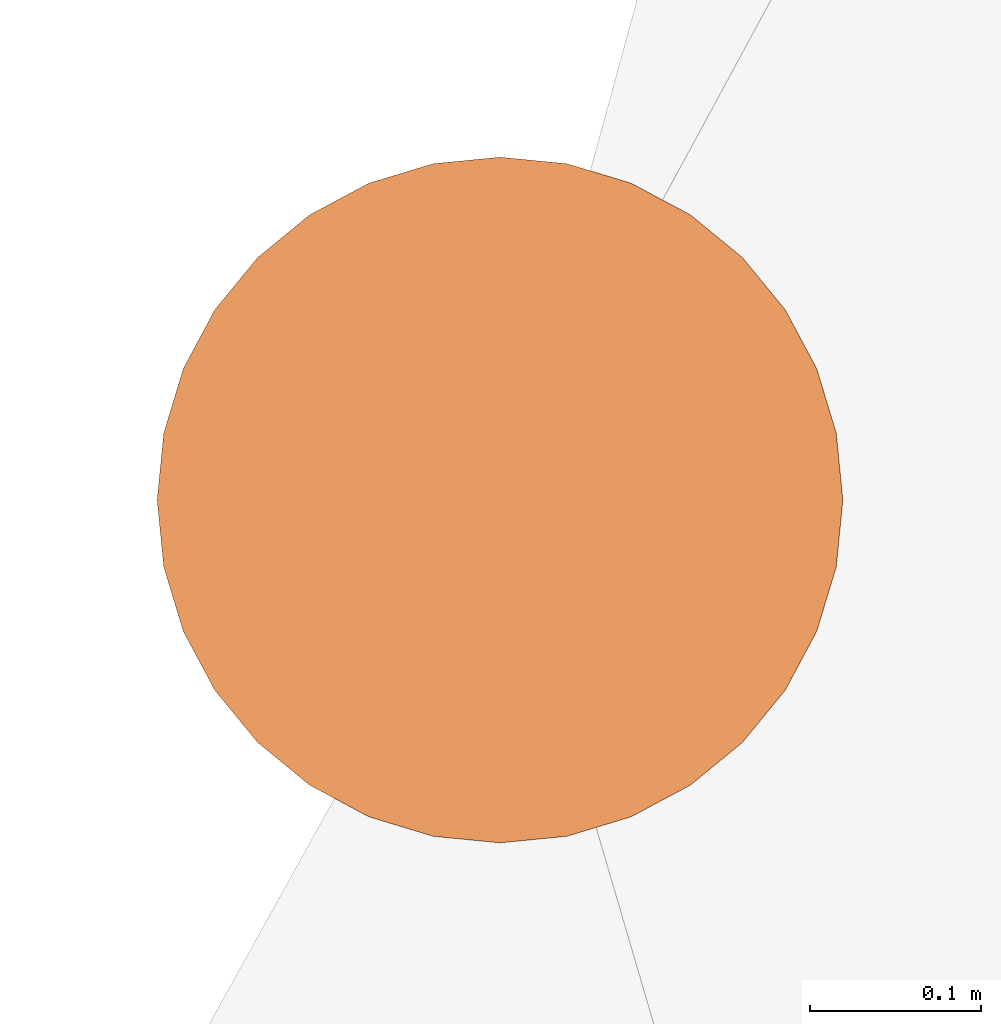
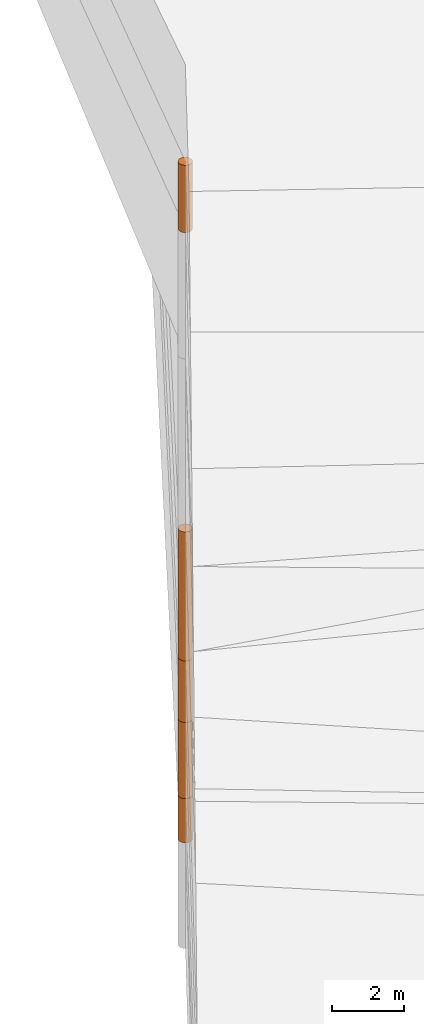
# One storey, part 10 of 24: 5 geographic elements.
"""IFC4 building model written with IfcOpenShell, lengths in metres."""

from ifc_helpers import new_model, entity, si_unit, converted_unit, frame, origin_with_axes, origin_2d_with_axis, place, context, subcontext, project, spatial, polygons, element, save


model = new_model("IFC4")

# Units and contexts
model_context = context("Model", 3, precision=1e-05, world=origin_with_axes())
plan_context = context("Plan", 2, precision=1e-05, world=origin_2d_with_axis())
body_context = subcontext(model_context, "Body", "Model", "MODEL_VIEW")
ifc_project = project(units=[converted_unit("PLANEANGLEUNIT", "degree", entity("IfcReal", 0.0174532925199433), si_unit("PLANEANGLEUNIT", "RADIAN"), dimensions=[0, 0, 0, 0, 0, 0, 0]), si_unit("AREAUNIT", "SQUARE_METRE"), si_unit("VOLUMEUNIT", "CUBIC_METRE"), si_unit("LENGTHUNIT", "METRE")], contexts=[model_context, plan_context])

# Site, building, storey
site_placement = place(None, origin_with_axes())
site = spatial("IfcSite", under=ifc_project, at=site_placement)
building_placement = place(site_placement, origin_with_axes())
building = spatial("IfcBuilding", under=site, at=building_placement, Name="Building")
storey_placement = place(building_placement, origin_with_axes())
storey = spatial("IfcBuildingStorey", under=building, at=storey_placement, Name="Storey")

# Geographic elements
geographic_element_1_placement = place(storey_placement, frame((0.699999988079071, 56.4000015258789, 14.952000617981), z_axis=(0.0, 0.0, 1.0), x_axis=(1.0, 0.0, 0.0)))
element("IfcGeographicElement", 1, at=geographic_element_1_placement, inside=storey, PredefinedType="NOTDEFINED", context=body_context, shape_type="Tessellation", body=[
    polygons([(0.0, 0.0, -1.14900004863739), (0.0390180610120296, 0.196157038211823, -1.14900004863739), (0.0, 0.199999988079071, -1.14900004863739), (0.0, 0.0, 1.14900004863739), (0.0, 0.199999988079071, 1.14900004863739), (0.0390180610120296, 0.196157038211823, 1.14900004863739), (0.0765366926789284, 0.18477588891983, -1.14900004863739), (0.0765366926789284, 0.18477588891983, 1.14900004863739), (0.111114047467709, 0.166293919086456, -1.14900004863739), (0.111114047467709, 0.166293919086456, 1.14900004863739), (0.141421362757683, 0.141421362757683, -1.14900004863739), (0.141421362757683, 0.141421362757683, 1.14900004863739), (0.166293919086456, 0.111114047467709, -1.14900004863739), (0.166293919086456, 0.111114047467709, 1.14900004863739), (0.18477588891983, 0.0765366926789284, -1.14900004863739), (0.18477588891983, 0.0765366926789284, 1.14900004863739), (0.196157038211823, 0.0390180610120296, -1.14900004863739), (0.196157038211823, 0.0390180610120296, 1.14900004863739), (0.199999988079071, 0.0, -1.14900004863739), (0.199999988079071, 0.0, 1.14900004863739), (0.196157038211823, -0.0390180610120296, -1.14900004863739), (0.196157038211823, -0.0390180610120296, 1.14900004863739), (0.18477588891983, -0.0765366926789284, -1.14900004863739), (0.18477588891983, -0.0765366926789284, 1.14900004863739), (0.166293919086456, -0.111114047467709, -1.14900004863739), (0.166293919086456, -0.111114047467709, 1.14900004863739), (0.141421362757683, -0.141421362757683, -1.14900004863739), (0.141421362757683, -0.141421362757683, 1.14900004863739), (0.111114047467709, -0.166293919086456, -1.14900004863739), (0.111114047467709, -0.166293919086456, 1.14900004863739), (0.0765366926789284, -0.18477588891983, -1.14900004863739), (0.0765366926789284, -0.18477588891983, 1.14900004863739), (0.0390180610120296, -0.196157038211823, -1.14900004863739), (0.0390180610120296, -0.196157038211823, 1.14900004863739), (0.0, -0.199999988079071, -1.14900004863739), (0.0, -0.199999988079071, 1.14900004863739), (-0.0390180610120296, -0.196157038211823, -1.14900004863739), (-0.0390180610120296, -0.196157038211823, 1.14900004863739), (-0.0765366926789284, -0.18477588891983, -1.14900004863739), (-0.0765366926789284, -0.18477588891983, 1.14900004863739), (-0.111114047467709, -0.166293919086456, -1.14900004863739), (-0.111114047467709, -0.166293919086456, 1.14900004863739), (-0.141421362757683, -0.141421362757683, -1.14900004863739), (-0.141421362757683, -0.141421362757683, 1.14900004863739), (-0.166293919086456, -0.111114047467709, -1.14900004863739), (-0.166293919086456, -0.111114047467709, 1.14900004863739), (-0.18477588891983, -0.0765366926789284, -1.14900004863739), (-0.18477588891983, -0.0765366926789284, 1.14900004863739), (-0.196157038211823, -0.0390180610120296, -1.14900004863739), (-0.196157038211823, -0.0390180610120296, 1.14900004863739), (-0.199999988079071, 0.0, -1.14900004863739), (-0.199999988079071, 0.0, 1.14900004863739), (-0.196157038211823, 0.0390180610120296, -1.14900004863739), (-0.196157038211823, 0.0390180610120296, 1.14900004863739), (-0.18477588891983, 0.0765366926789284, -1.14900004863739), (-0.18477588891983, 0.0765366926789284, 1.14900004863739), (-0.166293919086456, 0.111114047467709, -1.14900004863739), (-0.166293919086456, 0.111114047467709, 1.14900004863739), (-0.141421362757683, 0.141421362757683, -1.14900004863739), (-0.141421362757683, 0.141421362757683, 1.14900004863739), (-0.111114047467709, 0.166293919086456, -1.14900004863739), (-0.111114047467709, 0.166293919086456, 1.14900004863739), (-0.0765366926789284, 0.18477588891983, -1.14900004863739), (-0.0765366926789284, 0.18477588891983, 1.14900004863739), (-0.0390180610120296, 0.196157038211823, -1.14900004863739), (-0.0390180610120296, 0.196157038211823, 1.14900004863739)], [[[3, 2, 1]], [[6, 5, 4]], [[28, 30, 29, 27]], [[2, 7, 1]], [[8, 6, 4]], [[64, 66, 65, 63]], [[7, 9, 1]], [[10, 8, 4]], [[9, 11, 1]], [[12, 10, 4]], [[6, 8, 7, 2]], [[1, 11, 13]], [[12, 4, 14]], [[66, 5, 3, 65]], [[1, 13, 15]], [[4, 16, 14]], [[12, 14, 13, 11]], [[1, 15, 17]], [[4, 18, 16]], [[14, 16, 15, 13]], [[1, 17, 19]], [[4, 20, 18]], [[16, 18, 17, 15]], [[1, 19, 21]], [[4, 22, 20]], [[18, 20, 19, 17]], [[1, 21, 23]], [[4, 24, 22]], [[20, 22, 21, 19]], [[1, 23, 25]], [[4, 26, 24]], [[22, 24, 23, 21]], [[1, 25, 27]], [[4, 28, 26]], [[24, 26, 25, 23]], [[1, 27, 29]], [[28, 4, 30]], [[26, 28, 27, 25]], [[1, 29, 31]], [[4, 32, 30]], [[5, 6, 2, 3]], [[1, 31, 33]], [[4, 34, 32]], [[30, 32, 31, 29]], [[1, 33, 35]], [[4, 36, 34]], [[8, 10, 9, 7]], [[1, 35, 37]], [[4, 38, 36]], [[32, 34, 33, 31]], [[1, 37, 39]], [[4, 40, 38]], [[36, 38, 37, 35]], [[1, 39, 41]], [[4, 42, 40]], [[38, 40, 39, 37]], [[43, 1, 41]], [[4, 44, 42]], [[40, 42, 41, 39]], [[43, 45, 1]], [[4, 46, 44]], [[42, 44, 43, 41]], [[45, 47, 1]], [[48, 46, 4]], [[44, 46, 45, 43]], [[47, 49, 1]], [[50, 48, 4]], [[46, 48, 47, 45]], [[49, 51, 1]], [[52, 50, 4]], [[48, 50, 49, 47]], [[51, 53, 1]], [[54, 52, 4]], [[50, 52, 51, 49]], [[53, 55, 1]], [[56, 54, 4]], [[52, 54, 53, 51]], [[55, 57, 1]], [[58, 56, 4]], [[54, 56, 55, 53]], [[59, 1, 57]], [[60, 58, 4]], [[56, 58, 57, 55]], [[59, 61, 1]], [[62, 60, 4]], [[58, 60, 59, 57]], [[61, 63, 1]], [[64, 62, 4]], [[60, 62, 61, 59]], [[63, 65, 1]], [[66, 64, 4]], [[62, 64, 63, 61]], [[65, 3, 1]], [[5, 66, 4]], [[34, 36, 35, 33]], [[10, 12, 11, 9]]]),
])
geographic_element_2_placement = place(storey_placement, frame((0.700000047683716, 56.4000015258789, -6.23850202560425), z_axis=(0.0, 0.0, 1.0), x_axis=(1.0, 0.0, 0.0)))
element("IfcGeographicElement", 2, at=geographic_element_2_placement, inside=storey, PredefinedType="NOTDEFINED", context=body_context, shape_type="Tessellation", body=[
    polygons([(0.0, 0.0, -0.751500070095062), (0.0390180610120296, 0.196157038211823, -0.751500070095062), (0.0, 0.199999988079071, -0.751500070095062), (0.0, 0.0, 0.751500070095062), (0.0, 0.199999988079071, 0.751500070095062), (0.0390180610120296, 0.196157038211823, 0.751500070095062), (0.0765366926789284, 0.18477588891983, -0.751500070095062), (0.0765366926789284, 0.18477588891983, 0.751500070095062), (0.111114047467709, 0.166293919086456, -0.751500070095062), (0.111114047467709, 0.166293919086456, 0.751500070095062), (0.141421362757683, 0.141421362757683, -0.751500070095062), (0.141421362757683, 0.141421362757683, 0.751500070095062), (0.166293919086456, 0.111114047467709, -0.751500070095062), (0.166293919086456, 0.111114047467709, 0.751500070095062), (0.18477588891983, 0.0765366926789284, -0.751500070095062), (0.18477588891983, 0.0765366926789284, 0.751500070095062), (0.196157038211823, 0.0390180610120296, -0.751500070095062), (0.196157038211823, 0.0390180610120296, 0.751500070095062), (0.199999988079071, 0.0, -0.751500070095062), (0.199999988079071, 0.0, 0.751500070095062), (0.196157038211823, -0.0390180610120296, -0.751500070095062), (0.196157038211823, -0.0390180610120296, 0.751500070095062), (0.18477588891983, -0.0765366926789284, -0.751500070095062), (0.18477588891983, -0.0765366926789284, 0.751500070095062), (0.166293919086456, -0.111114047467709, -0.751500070095062), (0.166293919086456, -0.111114047467709, 0.751500070095062), (0.141421362757683, -0.141421362757683, -0.751500070095062), (0.141421362757683, -0.141421362757683, 0.751500070095062), (0.111114047467709, -0.166293919086456, -0.751500070095062), (0.111114047467709, -0.166293919086456, 0.751500070095062), (0.0765366926789284, -0.18477588891983, -0.751500070095062), (0.0765366926789284, -0.18477588891983, 0.751500070095062), (0.0390180610120296, -0.196157038211823, -0.751500070095062), (0.0390180610120296, -0.196157038211823, 0.751500070095062), (0.0, -0.199999988079071, -0.751500070095062), (0.0, -0.199999988079071, 0.751500070095062), (-0.0390180610120296, -0.196157038211823, -0.751500070095062), (-0.0390180610120296, -0.196157038211823, 0.751500070095062), (-0.0765366926789284, -0.18477588891983, -0.751500070095062), (-0.0765366926789284, -0.18477588891983, 0.751500070095062), (-0.111114047467709, -0.166293919086456, -0.751500070095062), (-0.111114047467709, -0.166293919086456, 0.751500070095062), (-0.141421362757683, -0.141421362757683, -0.751500070095062), (-0.141421362757683, -0.141421362757683, 0.751500070095062), (-0.166293919086456, -0.111114047467709, -0.751500070095062), (-0.166293919086456, -0.111114047467709, 0.751500070095062), (-0.18477588891983, -0.0765366926789284, -0.751500070095062), (-0.18477588891983, -0.0765366926789284, 0.751500070095062), (-0.196157038211823, -0.0390180610120296, -0.751500070095062), (-0.196157038211823, -0.0390180610120296, 0.751500070095062), (-0.199999988079071, 0.0, -0.751500070095062), (-0.199999988079071, 0.0, 0.751500070095062), (-0.196157038211823, 0.0390180610120296, -0.751500070095062), (-0.196157038211823, 0.0390180610120296, 0.751500070095062), (-0.18477588891983, 0.0765366926789284, -0.751500070095062), (-0.18477588891983, 0.0765366926789284, 0.751500070095062), (-0.166293919086456, 0.111114047467709, -0.751500070095062), (-0.166293919086456, 0.111114047467709, 0.751500070095062), (-0.141421362757683, 0.141421362757683, -0.751500070095062), (-0.141421362757683, 0.141421362757683, 0.751500070095062), (-0.111114047467709, 0.166293919086456, -0.751500070095062), (-0.111114047467709, 0.166293919086456, 0.751500070095062), (-0.0765366926789284, 0.18477588891983, -0.751500070095062), (-0.0765366926789284, 0.18477588891983, 0.751500070095062), (-0.0390180610120296, 0.196157038211823, -0.751500070095062), (-0.0390180610120296, 0.196157038211823, 0.751500070095062)], [[[3, 2, 1]], [[6, 5, 4]], [[28, 30, 29, 27]], [[2, 7, 1]], [[8, 6, 4]], [[64, 66, 65, 63]], [[7, 9, 1]], [[10, 8, 4]], [[9, 11, 1]], [[12, 10, 4]], [[6, 8, 7, 2]], [[1, 11, 13]], [[12, 4, 14]], [[66, 5, 3, 65]], [[1, 13, 15]], [[14, 4, 16]], [[12, 14, 13, 11]], [[1, 15, 17]], [[16, 4, 18]], [[14, 16, 15, 13]], [[1, 17, 19]], [[4, 20, 18]], [[16, 18, 17, 15]], [[1, 19, 21]], [[4, 22, 20]], [[18, 20, 19, 17]], [[1, 21, 23]], [[22, 4, 24]], [[20, 22, 21, 19]], [[1, 23, 25]], [[24, 4, 26]], [[22, 24, 23, 21]], [[27, 1, 25]], [[4, 28, 26]], [[24, 26, 25, 23]], [[1, 27, 29]], [[28, 4, 30]], [[26, 28, 27, 25]], [[1, 29, 31]], [[4, 32, 30]], [[5, 6, 2, 3]], [[1, 31, 33]], [[4, 34, 32]], [[30, 32, 31, 29]], [[1, 33, 35]], [[4, 36, 34]], [[8, 10, 9, 7]], [[1, 35, 37]], [[4, 38, 36]], [[32, 34, 33, 31]], [[1, 37, 39]], [[4, 40, 38]], [[36, 38, 37, 35]], [[1, 39, 41]], [[4, 42, 40]], [[38, 40, 39, 37]], [[43, 1, 41]], [[4, 44, 42]], [[40, 42, 41, 39]], [[43, 45, 1]], [[46, 44, 4]], [[42, 44, 43, 41]], [[47, 1, 45]], [[4, 48, 46]], [[44, 46, 45, 43]], [[49, 1, 47]], [[4, 50, 48]], [[46, 48, 47, 45]], [[49, 51, 1]], [[52, 50, 4]], [[48, 50, 49, 47]], [[51, 53, 1]], [[54, 52, 4]], [[50, 52, 51, 49]], [[55, 1, 53]], [[4, 56, 54]], [[52, 54, 53, 51]], [[57, 1, 55]], [[4, 58, 56]], [[54, 56, 55, 53]], [[57, 59, 1]], [[60, 58, 4]], [[56, 58, 57, 55]], [[59, 61, 1]], [[62, 60, 4]], [[58, 60, 59, 57]], [[61, 63, 1]], [[64, 62, 4]], [[60, 62, 61, 59]], [[63, 65, 1]], [[66, 64, 4]], [[62, 64, 63, 61]], [[65, 3, 1]], [[5, 66, 4]], [[34, 36, 35, 33]], [[10, 12, 11, 9]]]),
])
geographic_element_3_placement = place(storey_placement, frame((0.700000047683716, 56.4000015258789, -4.18800163269043), z_axis=(0.0, 0.0, 1.0), x_axis=(1.0, 0.0, 0.0)))
element("IfcGeographicElement", 3, at=geographic_element_3_placement, inside=storey, PredefinedType="NOTDEFINED", context=body_context, shape_type="Tessellation", body=[
    polygons([(0.0, 0.0, -1.29900014400482), (0.0390180610120296, 0.196157038211823, -1.29900014400482), (0.0, 0.199999988079071, -1.29900014400482), (0.0, 0.0, 1.29900014400482), (0.0, 0.199999988079071, 1.29900014400482), (0.0390180610120296, 0.196157038211823, 1.29900014400482), (0.0765366926789284, 0.18477588891983, -1.29900014400482), (0.0765366926789284, 0.18477588891983, 1.29900014400482), (0.111114047467709, 0.166293919086456, -1.29900014400482), (0.111114047467709, 0.166293919086456, 1.29900014400482), (0.141421362757683, 0.141421362757683, -1.29900014400482), (0.141421362757683, 0.141421362757683, 1.29900014400482), (0.166293919086456, 0.111114047467709, -1.29900014400482), (0.166293919086456, 0.111114047467709, 1.29900014400482), (0.18477588891983, 0.0765366926789284, -1.29900014400482), (0.18477588891983, 0.0765366926789284, 1.29900014400482), (0.196157038211823, 0.0390180610120296, -1.29900014400482), (0.196157038211823, 0.0390180610120296, 1.29900014400482), (0.199999988079071, 0.0, -1.29900014400482), (0.199999988079071, 0.0, 1.29900014400482), (0.196157038211823, -0.0390180610120296, -1.29900014400482), (0.196157038211823, -0.0390180610120296, 1.29900014400482), (0.18477588891983, -0.0765366926789284, -1.29900014400482), (0.18477588891983, -0.0765366926789284, 1.29900014400482), (0.166293919086456, -0.111114047467709, -1.29900014400482), (0.166293919086456, -0.111114047467709, 1.29900014400482), (0.141421362757683, -0.141421362757683, -1.29900014400482), (0.141421362757683, -0.141421362757683, 1.29900014400482), (0.111114047467709, -0.166293919086456, -1.29900014400482), (0.111114047467709, -0.166293919086456, 1.29900014400482), (0.0765366926789284, -0.18477588891983, -1.29900014400482), (0.0765366926789284, -0.18477588891983, 1.29900014400482), (0.0390180610120296, -0.196157038211823, -1.29900014400482), (0.0390180610120296, -0.196157038211823, 1.29900014400482), (0.0, -0.199999988079071, -1.29900014400482), (0.0, -0.199999988079071, 1.29900014400482), (-0.0390180610120296, -0.196157038211823, -1.29900014400482), (-0.0390180610120296, -0.196157038211823, 1.29900014400482), (-0.0765366926789284, -0.18477588891983, -1.29900014400482), (-0.0765366926789284, -0.18477588891983, 1.29900014400482), (-0.111114047467709, -0.166293919086456, -1.29900014400482), (-0.111114047467709, -0.166293919086456, 1.29900014400482), (-0.141421362757683, -0.141421362757683, -1.29900014400482), (-0.141421362757683, -0.141421362757683, 1.29900014400482), (-0.166293919086456, -0.111114047467709, -1.29900014400482), (-0.166293919086456, -0.111114047467709, 1.29900014400482), (-0.18477588891983, -0.0765366926789284, -1.29900014400482), (-0.18477588891983, -0.0765366926789284, 1.29900014400482), (-0.196157038211823, -0.0390180610120296, -1.29900014400482), (-0.196157038211823, -0.0390180610120296, 1.29900014400482), (-0.199999988079071, 0.0, -1.29900014400482), (-0.199999988079071, 0.0, 1.29900014400482), (-0.196157038211823, 0.0390180610120296, -1.29900014400482), (-0.196157038211823, 0.0390180610120296, 1.29900014400482), (-0.18477588891983, 0.0765366926789284, -1.29900014400482), (-0.18477588891983, 0.0765366926789284, 1.29900014400482), (-0.166293919086456, 0.111114047467709, -1.29900014400482), (-0.166293919086456, 0.111114047467709, 1.29900014400482), (-0.141421362757683, 0.141421362757683, -1.29900014400482), (-0.141421362757683, 0.141421362757683, 1.29900014400482), (-0.111114047467709, 0.166293919086456, -1.29900014400482), (-0.111114047467709, 0.166293919086456, 1.29900014400482), (-0.0765366926789284, 0.18477588891983, -1.29900014400482), (-0.0765366926789284, 0.18477588891983, 1.29900014400482), (-0.0390180610120296, 0.196157038211823, -1.29900014400482), (-0.0390180610120296, 0.196157038211823, 1.29900014400482)], [[[3, 2, 1]], [[6, 5, 4]], [[28, 30, 29, 27]], [[2, 7, 1]], [[8, 6, 4]], [[64, 66, 65, 63]], [[7, 9, 1]], [[10, 8, 4]], [[9, 11, 1]], [[12, 10, 4]], [[6, 8, 7, 2]], [[1, 11, 13]], [[12, 4, 14]], [[66, 5, 3, 65]], [[1, 13, 15]], [[4, 16, 14]], [[12, 14, 13, 11]], [[1, 15, 17]], [[4, 18, 16]], [[14, 16, 15, 13]], [[1, 17, 19]], [[4, 20, 18]], [[16, 18, 17, 15]], [[1, 19, 21]], [[4, 22, 20]], [[18, 20, 19, 17]], [[1, 21, 23]], [[4, 24, 22]], [[20, 22, 21, 19]], [[1, 23, 25]], [[4, 26, 24]], [[22, 24, 23, 21]], [[27, 1, 25]], [[4, 28, 26]], [[24, 26, 25, 23]], [[1, 27, 29]], [[28, 4, 30]], [[26, 28, 27, 25]], [[1, 29, 31]], [[4, 32, 30]], [[5, 6, 2, 3]], [[1, 31, 33]], [[4, 34, 32]], [[30, 32, 31, 29]], [[1, 33, 35]], [[4, 36, 34]], [[8, 10, 9, 7]], [[1, 35, 37]], [[4, 38, 36]], [[32, 34, 33, 31]], [[1, 37, 39]], [[4, 40, 38]], [[36, 38, 37, 35]], [[1, 39, 41]], [[4, 42, 40]], [[38, 40, 39, 37]], [[43, 1, 41]], [[4, 44, 42]], [[40, 42, 41, 39]], [[43, 45, 1]], [[46, 44, 4]], [[42, 44, 43, 41]], [[45, 47, 1]], [[48, 46, 4]], [[44, 46, 45, 43]], [[47, 49, 1]], [[50, 48, 4]], [[46, 48, 47, 45]], [[49, 51, 1]], [[52, 50, 4]], [[48, 50, 49, 47]], [[51, 53, 1]], [[54, 52, 4]], [[50, 52, 51, 49]], [[53, 55, 1]], [[56, 54, 4]], [[52, 54, 53, 51]], [[55, 57, 1]], [[58, 56, 4]], [[54, 56, 55, 53]], [[57, 59, 1]], [[60, 58, 4]], [[56, 58, 57, 55]], [[59, 61, 1]], [[62, 60, 4]], [[58, 60, 59, 57]], [[61, 63, 1]], [[64, 62, 4]], [[60, 62, 61, 59]], [[63, 65, 1]], [[66, 64, 4]], [[62, 64, 63, 61]], [[65, 3, 1]], [[5, 66, 4]], [[34, 36, 35, 33]], [[10, 12, 11, 9]]]),
])
geographic_element_4_placement = place(storey_placement, frame((0.700000047683716, 56.4000015258789, -1.8400012254715), z_axis=(0.0, 0.0, 1.0), x_axis=(1.0, 0.0, 0.0)))
element("IfcGeographicElement", 4, at=geographic_element_4_placement, inside=storey, PredefinedType="NOTDEFINED", context=body_context, shape_type="Tessellation", body=[
    polygons([(0.0, 0.0, -1.04900014400482), (0.0390180610120296, 0.196157038211823, -1.04900014400482), (0.0, 0.199999988079071, -1.04900014400482), (0.0, 0.0, 1.04900014400482), (0.0, 0.199999988079071, 1.04900014400482), (0.0390180610120296, 0.196157038211823, 1.04900014400482), (0.0765366926789284, 0.18477588891983, -1.04900014400482), (0.0765366926789284, 0.18477588891983, 1.04900014400482), (0.111114047467709, 0.166293919086456, -1.04900014400482), (0.111114047467709, 0.166293919086456, 1.04900014400482), (0.141421362757683, 0.141421362757683, -1.04900014400482), (0.141421362757683, 0.141421362757683, 1.04900014400482), (0.166293919086456, 0.111114047467709, -1.04900014400482), (0.166293919086456, 0.111114047467709, 1.04900014400482), (0.18477588891983, 0.0765366926789284, -1.04900014400482), (0.18477588891983, 0.0765366926789284, 1.04900014400482), (0.196157038211823, 0.0390180610120296, -1.04900014400482), (0.196157038211823, 0.0390180610120296, 1.04900014400482), (0.199999988079071, 0.0, -1.04900014400482), (0.199999988079071, 0.0, 1.04900014400482), (0.196157038211823, -0.0390180610120296, -1.04900014400482), (0.196157038211823, -0.0390180610120296, 1.04900014400482), (0.18477588891983, -0.0765366926789284, -1.04900014400482), (0.18477588891983, -0.0765366926789284, 1.04900014400482), (0.166293919086456, -0.111114047467709, -1.04900014400482), (0.166293919086456, -0.111114047467709, 1.04900014400482), (0.141421362757683, -0.141421362757683, -1.04900014400482), (0.141421362757683, -0.141421362757683, 1.04900014400482), (0.111114047467709, -0.166293919086456, -1.04900014400482), (0.111114047467709, -0.166293919086456, 1.04900014400482), (0.0765366926789284, -0.18477588891983, -1.04900014400482), (0.0765366926789284, -0.18477588891983, 1.04900014400482), (0.0390180610120296, -0.196157038211823, -1.04900014400482), (0.0390180610120296, -0.196157038211823, 1.04900014400482), (0.0, -0.199999988079071, -1.04900014400482), (0.0, -0.199999988079071, 1.04900014400482), (-0.0390180610120296, -0.196157038211823, -1.04900014400482), (-0.0390180610120296, -0.196157038211823, 1.04900014400482), (-0.0765366926789284, -0.18477588891983, -1.04900014400482), (-0.0765366926789284, -0.18477588891983, 1.04900014400482), (-0.111114047467709, -0.166293919086456, -1.04900014400482), (-0.111114047467709, -0.166293919086456, 1.04900014400482), (-0.141421362757683, -0.141421362757683, -1.04900014400482), (-0.141421362757683, -0.141421362757683, 1.04900014400482), (-0.166293919086456, -0.111114047467709, -1.04900014400482), (-0.166293919086456, -0.111114047467709, 1.04900014400482), (-0.18477588891983, -0.0765366926789284, -1.04900014400482), (-0.18477588891983, -0.0765366926789284, 1.04900014400482), (-0.196157038211823, -0.0390180610120296, -1.04900014400482), (-0.196157038211823, -0.0390180610120296, 1.04900014400482), (-0.199999988079071, 0.0, -1.04900014400482), (-0.199999988079071, 0.0, 1.04900014400482), (-0.196157038211823, 0.0390180610120296, -1.04900014400482), (-0.196157038211823, 0.0390180610120296, 1.04900014400482), (-0.18477588891983, 0.0765366926789284, -1.04900014400482), (-0.18477588891983, 0.0765366926789284, 1.04900014400482), (-0.166293919086456, 0.111114047467709, -1.04900014400482), (-0.166293919086456, 0.111114047467709, 1.04900014400482), (-0.141421362757683, 0.141421362757683, -1.04900014400482), (-0.141421362757683, 0.141421362757683, 1.04900014400482), (-0.111114047467709, 0.166293919086456, -1.04900014400482), (-0.111114047467709, 0.166293919086456, 1.04900014400482), (-0.0765366926789284, 0.18477588891983, -1.04900014400482), (-0.0765366926789284, 0.18477588891983, 1.04900014400482), (-0.0390180610120296, 0.196157038211823, -1.04900014400482), (-0.0390180610120296, 0.196157038211823, 1.04900014400482)], [[[3, 2, 1]], [[6, 5, 4]], [[62, 64, 63, 61]], [[2, 7, 1]], [[8, 6, 4]], [[30, 32, 31, 29]], [[7, 9, 1]], [[10, 8, 4]], [[10, 12, 11, 9]], [[9, 11, 1]], [[12, 10, 4]], [[11, 13, 1]], [[12, 4, 14]], [[66, 5, 3, 65]], [[1, 13, 15]], [[4, 16, 14]], [[42, 44, 43, 41]], [[1, 15, 17]], [[16, 4, 18]], [[48, 50, 49, 47]], [[1, 17, 19]], [[4, 20, 18]], [[16, 18, 17, 15]], [[1, 19, 21]], [[20, 4, 22]], [[50, 52, 51, 49]], [[1, 21, 23]], [[4, 24, 22]], [[54, 56, 55, 53]], [[1, 23, 25]], [[4, 26, 24]], [[56, 58, 57, 55]], [[27, 1, 25]], [[26, 4, 28]], [[58, 60, 59, 57]], [[1, 27, 29]], [[28, 4, 30]], [[60, 62, 61, 59]], [[1, 29, 31]], [[4, 32, 30]], [[64, 66, 65, 63]], [[1, 31, 33]], [[4, 34, 32]], [[6, 8, 7, 2]], [[1, 33, 35]], [[4, 36, 34]], [[8, 10, 9, 7]], [[1, 35, 37]], [[4, 38, 36]], [[32, 34, 33, 31]], [[1, 37, 39]], [[4, 40, 38]], [[36, 38, 37, 35]], [[1, 39, 41]], [[4, 42, 40]], [[46, 48, 47, 45]], [[43, 1, 41]], [[4, 44, 42]], [[34, 36, 35, 33]], [[45, 1, 43]], [[46, 44, 4]], [[14, 16, 15, 13]], [[45, 47, 1]], [[48, 46, 4]], [[44, 46, 45, 43]], [[47, 49, 1]], [[4, 50, 48]], [[40, 42, 41, 39]], [[51, 1, 49]], [[52, 50, 4]], [[18, 20, 19, 17]], [[51, 53, 1]], [[4, 54, 52]], [[20, 22, 21, 19]], [[55, 1, 53]], [[56, 54, 4]], [[52, 54, 53, 51]], [[55, 57, 1]], [[58, 56, 4]], [[22, 24, 23, 21]], [[57, 59, 1]], [[60, 58, 4]], [[24, 26, 25, 23]], [[59, 61, 1]], [[62, 60, 4]], [[26, 28, 27, 25]], [[61, 63, 1]], [[64, 62, 4]], [[28, 30, 29, 27]], [[63, 65, 1]], [[66, 64, 4]], [[5, 6, 2, 3]], [[65, 3, 1]], [[5, 66, 4]], [[38, 40, 39, 37]], [[12, 14, 13, 11]]]),
])
geographic_element_5_placement = place(storey_placement, frame((0.699999988079071, 56.4000015258789, 1.40799903869629), z_axis=(0.0, 0.0, 1.0), x_axis=(1.0, 0.0, 0.0)))
element("IfcGeographicElement", 5, at=geographic_element_5_placement, inside=storey, PredefinedType="NOTDEFINED", context=body_context, shape_type="Tessellation", body=[
    polygons([(0.0, 0.0, -2.19899988174438), (0.0390180610120296, 0.196157038211823, -2.19899988174438), (0.0, 0.199999988079071, -2.19899988174438), (0.0, 0.0, 2.19899988174438), (0.0, 0.199999988079071, 2.19899988174438), (0.0390180610120296, 0.196157038211823, 2.19899988174438), (0.0765366926789284, 0.18477588891983, -2.19899988174438), (0.0765366926789284, 0.18477588891983, 2.19899988174438), (0.111114047467709, 0.166293919086456, -2.19899988174438), (0.111114047467709, 0.166293919086456, 2.19899988174438), (0.141421362757683, 0.141421362757683, -2.19899988174438), (0.141421362757683, 0.141421362757683, 2.19899988174438), (0.166293919086456, 0.111114047467709, -2.19899988174438), (0.166293919086456, 0.111114047467709, 2.19899988174438), (0.18477588891983, 0.0765366926789284, -2.19899988174438), (0.18477588891983, 0.0765366926789284, 2.19899988174438), (0.196157038211823, 0.0390180610120296, -2.19899988174438), (0.196157038211823, 0.0390180610120296, 2.19899988174438), (0.199999988079071, 0.0, -2.19899988174438), (0.199999988079071, 0.0, 2.19899988174438), (0.196157038211823, -0.0390180610120296, -2.19899988174438), (0.196157038211823, -0.0390180610120296, 2.19899988174438), (0.18477588891983, -0.0765366926789284, -2.19899988174438), (0.18477588891983, -0.0765366926789284, 2.19899988174438), (0.166293919086456, -0.111114047467709, -2.19899988174438), (0.166293919086456, -0.111114047467709, 2.19899988174438), (0.141421362757683, -0.141421362757683, -2.19899988174438), (0.141421362757683, -0.141421362757683, 2.19899988174438), (0.111114047467709, -0.166293919086456, -2.19899988174438), (0.111114047467709, -0.166293919086456, 2.19899988174438), (0.0765366926789284, -0.18477588891983, -2.19899988174438), (0.0765366926789284, -0.18477588891983, 2.19899988174438), (0.0390180610120296, -0.196157038211823, -2.19899988174438), (0.0390180610120296, -0.196157038211823, 2.19899988174438), (0.0, -0.199999988079071, -2.19899988174438), (0.0, -0.199999988079071, 2.19899988174438), (-0.0390180610120296, -0.196157038211823, -2.19899988174438), (-0.0390180610120296, -0.196157038211823, 2.19899988174438), (-0.0765366926789284, -0.18477588891983, -2.19899988174438), (-0.0765366926789284, -0.18477588891983, 2.19899988174438), (-0.111114047467709, -0.166293919086456, -2.19899988174438), (-0.111114047467709, -0.166293919086456, 2.19899988174438), (-0.141421362757683, -0.141421362757683, -2.19899988174438), (-0.141421362757683, -0.141421362757683, 2.19899988174438), (-0.166293919086456, -0.111114047467709, -2.19899988174438), (-0.166293919086456, -0.111114047467709, 2.19899988174438), (-0.18477588891983, -0.0765366926789284, -2.19899988174438), (-0.18477588891983, -0.0765366926789284, 2.19899988174438), (-0.196157038211823, -0.0390180610120296, -2.19899988174438), (-0.196157038211823, -0.0390180610120296, 2.19899988174438), (-0.199999988079071, 0.0, -2.19899988174438), (-0.199999988079071, 0.0, 2.19899988174438), (-0.196157038211823, 0.0390180610120296, -2.19899988174438), (-0.196157038211823, 0.0390180610120296, 2.19899988174438), (-0.18477588891983, 0.0765366926789284, -2.19899988174438), (-0.18477588891983, 0.0765366926789284, 2.19899988174438), (-0.166293919086456, 0.111114047467709, -2.19899988174438), (-0.166293919086456, 0.111114047467709, 2.19899988174438), (-0.141421362757683, 0.141421362757683, -2.19899988174438), (-0.141421362757683, 0.141421362757683, 2.19899988174438), (-0.111114047467709, 0.166293919086456, -2.19899988174438), (-0.111114047467709, 0.166293919086456, 2.19899988174438), (-0.0765366926789284, 0.18477588891983, -2.19899988174438), (-0.0765366926789284, 0.18477588891983, 2.19899988174438), (-0.0390180610120296, 0.196157038211823, -2.19899988174438), (-0.0390180610120296, 0.196157038211823, 2.19899988174438)], [[[3, 2, 1]], [[6, 5, 4]], [[28, 30, 29, 27]], [[2, 7, 1]], [[8, 6, 4]], [[64, 66, 65, 63]], [[7, 9, 1]], [[10, 8, 4]], [[9, 11, 1]], [[12, 10, 4]], [[6, 8, 7, 2]], [[1, 11, 13]], [[12, 4, 14]], [[66, 5, 3, 65]], [[1, 13, 15]], [[4, 16, 14]], [[12, 14, 13, 11]], [[1, 15, 17]], [[4, 18, 16]], [[14, 16, 15, 13]], [[1, 17, 19]], [[4, 20, 18]], [[16, 18, 17, 15]], [[1, 19, 21]], [[4, 22, 20]], [[18, 20, 19, 17]], [[1, 21, 23]], [[22, 4, 24]], [[20, 22, 21, 19]], [[1, 23, 25]], [[24, 4, 26]], [[22, 24, 23, 21]], [[27, 1, 25]], [[4, 28, 26]], [[24, 26, 25, 23]], [[1, 27, 29]], [[28, 4, 30]], [[26, 28, 27, 25]], [[1, 29, 31]], [[4, 32, 30]], [[5, 6, 2, 3]], [[1, 31, 33]], [[4, 34, 32]], [[30, 32, 31, 29]], [[1, 33, 35]], [[4, 36, 34]], [[8, 10, 9, 7]], [[1, 35, 37]], [[4, 38, 36]], [[32, 34, 33, 31]], [[1, 37, 39]], [[4, 40, 38]], [[36, 38, 37, 35]], [[1, 39, 41]], [[4, 42, 40]], [[38, 40, 39, 37]], [[43, 1, 41]], [[4, 44, 42]], [[40, 42, 41, 39]], [[43, 45, 1]], [[46, 44, 4]], [[42, 44, 43, 41]], [[47, 1, 45]], [[48, 46, 4]], [[44, 46, 45, 43]], [[49, 1, 47]], [[50, 48, 4]], [[46, 48, 47, 45]], [[49, 51, 1]], [[52, 50, 4]], [[48, 50, 49, 47]], [[51, 53, 1]], [[54, 52, 4]], [[50, 52, 51, 49]], [[53, 55, 1]], [[4, 56, 54]], [[52, 54, 53, 51]], [[55, 57, 1]], [[4, 58, 56]], [[54, 56, 55, 53]], [[57, 59, 1]], [[60, 58, 4]], [[56, 58, 57, 55]], [[59, 61, 1]], [[62, 60, 4]], [[58, 60, 59, 57]], [[61, 63, 1]], [[64, 62, 4]], [[60, 62, 61, 59]], [[63, 65, 1]], [[66, 64, 4]], [[62, 64, 63, 61]], [[65, 3, 1]], [[5, 66, 4]], [[34, 36, 35, 33]], [[10, 12, 11, 9]]]),
])

save(model, "model.ifc")
